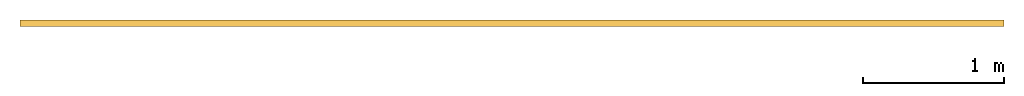
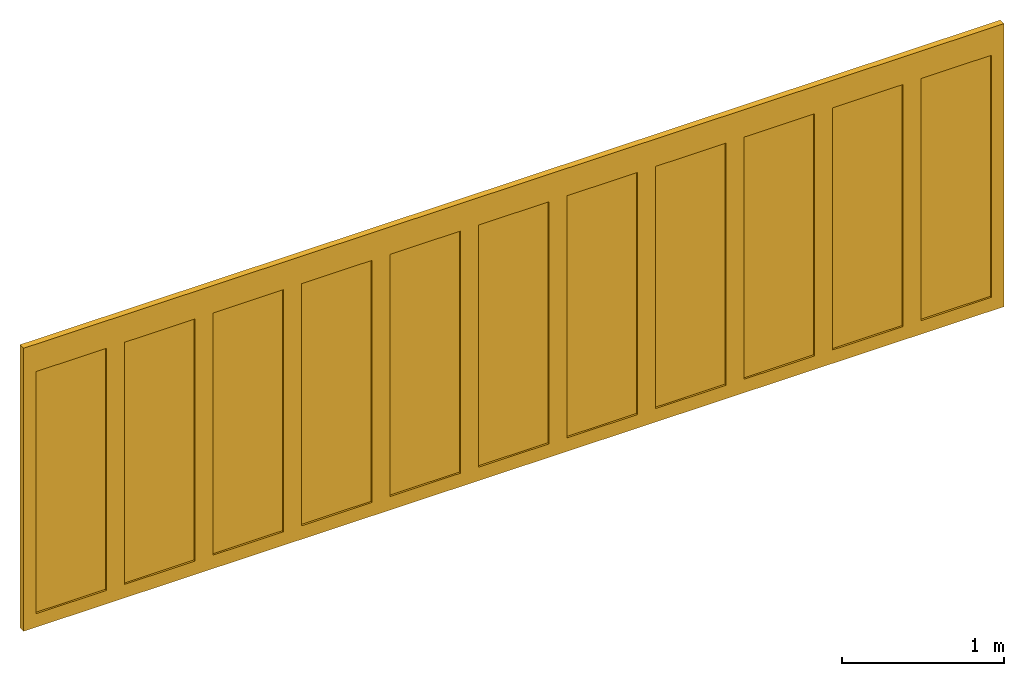
# One storey: 1 door.
"""IFC2X3 building model written with IfcOpenShell, lengths in millimetres."""

from ifc_helpers import new_model, entity, si_unit, converted_unit, direction, frame, frame_2d, origin, place, context, subcontext, project, spatial, polyline, rectangle, outline, extrude, source, transform, mapped, material, material_list, type_object, type_shapes, element, save


model = new_model("IFC2X3")

# Units and contexts
model_context = context("Model", 3, precision=1e-06, world=origin(), true_north=direction((2.0, -1.71512652170913e-15, 1.0)))
context_of_model = context(None, 3, precision=1e-06, world=origin(), true_north=direction((2.0, -1.71512652170913e-15, 1.0)))
body_context = subcontext(model_context, "Body", "Model", "MODEL_VIEW")
ifc_project = project(units=[si_unit("LENGTHUNIT", "METRE", prefix="MILLI"), si_unit("AREAUNIT", "SQUARE_METRE", prefix="MILLI"), si_unit("VOLUMEUNIT", "CUBIC_METRE", prefix="MILLI"), converted_unit("PLANEANGLEUNIT", "DEGREE", entity("IfcRatioMeasure", 0.0174532925199433), si_unit("PLANEANGLEUNIT", "RADIAN"), dimensions=[0, 0, 0, 0, 0, 0, 0]), si_unit("TIMEUNIT", "SECOND")], contexts=[model_context, context_of_model])

# Site, building, storey
site_placement = place(None, origin())
site = spatial("IfcSite", under=ifc_project, at=site_placement, CompositionType="ELEMENT")
building_placement = place(site_placement, origin())
building = spatial("IfcBuilding", under=site, at=building_placement, CompositionType="ELEMENT")
storey_placement = place(building_placement, origin())
storey = spatial("IfcBuildingStorey", under=building, at=storey_placement, Name="Ground Floor", CompositionType="ELEMENT", Elevation=0.0)

# Door
ifc_material_1 = material(Name="Glass-Blue")
ifc_material_2 = material(Name="Mtl-Aluminium")
ifc_material_list = material_list([ifc_material_1, ifc_material_2])
door_style = type_object("IfcDoorStyle", ConstructionType="NOTDEFINED", OperationType="NOTDEFINED", ParameterTakesPrecedence=False, Sizeable=False)
shared_shape = source(origin(), body_context, "Body", "SweptSolid", [
    extrude(rectangle(XDim=502.000000000001, YDim=18.0, at=frame_2d((0.0, 1.68753899743024e-14), x_axis=(1.0, 0.0))), frame((2110.3148, 277.500000000017, 65.0), z_axis=(0.0, 0.0, 1.0), x_axis=(-1.0, 0.0, 0.0)), (0.0, 0.0, 1.0), 1827.8),
    extrude(outline(polyline([(-316.0, -978.9), (316.0, -978.9), (316.0, 978.9), (-316.0, 978.9), (-316.0, -978.9)]), holes=[polyline([(251.0, 913.9), (251.0, -913.9), (-251.0, -913.9), (-251.0, 913.9), (251.0, 913.9)])]), frame((2110.3148, 255.0, 978.9), z_axis=(0.0, 1.0, 0.0), x_axis=(-1.0, 0.0, 0.0)), (0.0, 0.0, 1.0), 45.0),
    extrude(rectangle(XDim=502.0, YDim=18.0, at=frame_2d((0.0, 1.68753899743024e-14), x_axis=(1.0, 0.0))), frame((1478.3148, 277.500000000017, 65.0), z_axis=(0.0, 0.0, 1.0), x_axis=(-1.0, 0.0, 0.0)), (0.0, 0.0, 1.0), 1827.8),
    extrude(outline(polyline([(-316.0, -978.9), (316.0, -978.9), (316.0, 978.9), (-316.0, 978.9), (-316.0, -978.9)]), holes=[polyline([(251.0, 913.9), (251.0, -913.9), (-251.0, -913.9), (-251.0, 913.9), (251.0, 913.9)])]), frame((1478.3148, 255.0, 978.9), z_axis=(0.0, 1.0, 0.0), x_axis=(-1.0, 0.0, 0.0)), (0.0, 0.0, 1.0), 45.0),
    extrude(rectangle(XDim=502.0, YDim=18.0, at=frame_2d((0.0, 1.68753899743024e-14), x_axis=(1.0, 0.0))), frame((846.314800000002, 277.500000000017, 65.0), z_axis=(0.0, 0.0, 1.0), x_axis=(-1.0, 0.0, 0.0)), (0.0, 0.0, 1.0), 1827.8),
    extrude(outline(polyline([(-316.0, -978.9), (316.0, -978.9), (316.0, 978.9), (-316.0, 978.9), (-316.0, -978.9)]), holes=[polyline([(251.0, 913.9), (251.0, -913.9), (-251.0, -913.9), (-251.0, 913.9), (251.0, 913.9)])]), frame((846.314800000002, 255.0, 978.9), z_axis=(0.0, 1.0, 0.0), x_axis=(-1.0, 0.0, 0.0)), (0.0, 0.0, 1.0), 45.0),
    extrude(rectangle(XDim=502.000000000001, YDim=18.0, at=frame_2d((0.0, 1.68753899743024e-14), x_axis=(1.0, 0.0))), frame((214.314800000002, 277.500000000017, 65.0), z_axis=(0.0, 0.0, 1.0), x_axis=(-1.0, 0.0, 0.0)), (0.0, 0.0, 1.0), 1827.8),
    extrude(outline(polyline([(-316.0, -978.9), (316.0, -978.9), (316.0, 978.9), (-316.0, 978.9), (-316.0, -978.9)]), holes=[polyline([(251.0, 913.9), (251.0, -913.9), (-251.0, -913.9), (-251.0, 913.9), (251.0, 913.9)])]), frame((214.314800000002, 255.0, 978.9), z_axis=(0.0, 1.0, 0.0), x_axis=(-1.0, 0.0, 0.0)), (0.0, 0.0, 1.0), 45.0),
    extrude(rectangle(XDim=502.0, YDim=18.0, at=frame_2d((0.0, 1.68753899743024e-14), x_axis=(1.0, 0.0))), frame((-417.685199999998, 277.500000000017, 65.0), z_axis=(0.0, 0.0, 1.0), x_axis=(-1.0, 0.0, 0.0)), (0.0, 0.0, 1.0), 1827.8),
    extrude(outline(polyline([(-316.0, -978.9), (316.0, -978.9), (316.0, 978.9), (-316.0, 978.9), (-316.0, -978.9)]), holes=[polyline([(251.0, 913.9), (251.0, -913.9), (-251.0, -913.9), (-251.0, 913.9), (251.0, 913.9)])]), frame((-417.685199999998, 255.0, 978.9), z_axis=(0.0, 1.0, 0.0), x_axis=(-1.0, 0.0, 0.0)), (0.0, 0.0, 1.0), 45.0),
    extrude(rectangle(XDim=502.0, YDim=18.0, at=frame_2d((0.0, 1.68753899743024e-14), x_axis=(1.0, 0.0))), frame((-1049.6852, 277.500000000017, 65.0), z_axis=(0.0, 0.0, 1.0), x_axis=(-1.0, 0.0, 0.0)), (0.0, 0.0, 1.0), 1827.8),
    extrude(outline(polyline([(-316.0, -978.9), (316.0, -978.9), (316.0, 978.9), (-316.0, 978.9), (-316.0, -978.9)]), holes=[polyline([(251.0, 913.9), (251.0, -913.9), (-251.0, -913.9), (-251.0, 913.9), (251.0, 913.9)])]), frame((-1049.6852, 255.0, 978.9), z_axis=(0.0, 1.0, 0.0), x_axis=(-1.0, 0.0, 0.0)), (0.0, 0.0, 1.0), 45.0),
    extrude(rectangle(XDim=502.0, YDim=18.0, at=frame_2d((-2.70006239588838e-13, 1.68753899743024e-14), x_axis=(1.0, 0.0))), frame((-1681.6852, 277.500000000017, 65.0), z_axis=(0.0, 0.0, 1.0), x_axis=(-1.0, 0.0, 0.0)), (0.0, 0.0, 1.0), 1827.8),
    extrude(outline(polyline([(-316.0, -978.9), (316.0, -978.9), (316.0, 978.9), (-316.0, 978.9), (-316.0, -978.9)]), holes=[polyline([(251.0, 913.9), (251.0, -913.9), (-251.0, -913.9), (-251.0, 913.9), (251.0, 913.9)])]), frame((-1681.6852, 255.0, 978.9), z_axis=(0.0, 1.0, 0.0), x_axis=(-1.0, 0.0, 0.0)), (0.0, 0.0, 1.0), 45.0),
    extrude(rectangle(XDim=502.0, YDim=18.0, at=frame_2d((0.0, 1.68753899743024e-14), x_axis=(1.0, 0.0))), frame((-2313.6852, 277.500000000017, 65.0), z_axis=(0.0, 0.0, 1.0), x_axis=(-1.0, 0.0, 0.0)), (0.0, 0.0, 1.0), 1827.8),
    extrude(outline(polyline([(-316.0, -978.9), (316.0, -978.9), (316.0, 978.9), (-316.0, 978.9), (-316.0, -978.9)]), holes=[polyline([(251.0, 913.9), (251.0, -913.9), (-251.0, -913.9), (-251.0, 913.9), (251.0, 913.9)])]), frame((-2313.6852, 255.0, 978.9), z_axis=(0.0, 1.0, 0.0), x_axis=(-1.0, 0.0, 0.0)), (0.0, 0.0, 1.0), 45.0),
    extrude(rectangle(XDim=502.0, YDim=18.0, at=frame_2d((0.0, 1.68753899743024e-14), x_axis=(1.0, 0.0))), frame((-2945.6852, 277.500000000017, 65.0), z_axis=(0.0, 0.0, 1.0), x_axis=(-1.0, 0.0, 0.0)), (0.0, 0.0, 1.0), 1827.8),
    extrude(outline(polyline([(-316.0, -978.9), (316.0, -978.9), (316.0, 978.9), (-316.0, 978.9), (-316.0, -978.9)]), holes=[polyline([(251.0, 913.9), (251.0, -913.9), (-251.0, -913.9), (-251.0, 913.9), (251.0, 913.9)])]), frame((-2945.6852, 255.0, 978.9), z_axis=(0.0, 1.0, 0.0), x_axis=(-1.0, 0.0, 0.0)), (0.0, 0.0, 1.0), 45.0),
    extrude(rectangle(XDim=502.0, YDim=18.0, at=frame_2d((2.70006239588838e-13, 1.68753899743024e-14), x_axis=(1.0, 0.0))), frame((-3577.6852, 277.500000000017, 65.0), z_axis=(0.0, 0.0, 1.0), x_axis=(-1.0, 0.0, 0.0)), (0.0, 0.0, 1.0), 1827.8),
    extrude(outline(polyline([(-316.0, -978.9), (316.0, -978.9), (316.0, 978.9), (-316.0, 978.9), (-316.0, -978.9)]), holes=[polyline([(251.0, 913.9), (251.0, -913.9), (-251.0, -913.9), (-251.0, 913.9), (251.0, 913.9)])]), frame((-3577.6852, 255.0, 978.9), z_axis=(0.0, 1.0, 0.0), x_axis=(-1.0, 0.0, 0.0)), (0.0, 0.0, 1.0), 45.0),
    extrude(rectangle(XDim=502.0, YDim=18.0, at=frame_2d((-2.70006239588838e-13, 1.68753899743024e-14), x_axis=(1.0, 0.0))), frame((-4209.6852, 277.500000000017, 65.0), z_axis=(0.0, 0.0, 1.0), x_axis=(-1.0, 0.0, 0.0)), (0.0, 0.0, 1.0), 1827.8),
    extrude(outline(polyline([(-316.0, -978.9), (316.0, -978.9), (316.0, 978.9), (-316.0, 978.9), (-316.0, -978.9)]), holes=[polyline([(251.0, 913.9), (251.0, -913.9), (-251.0, -913.9), (-251.0, 913.9), (251.0, 913.9)])]), frame((-4209.6852, 255.0, 978.9), z_axis=(0.0, 1.0, 0.0), x_axis=(-1.0, 0.0, 0.0)), (0.0, 0.0, 1.0), 45.0),
    extrude(rectangle(XDim=24.0, YDim=45.0, at=frame_2d((0.0, -1.59872115546023e-14), x_axis=(1.0, 0.0))), frame((-4537.6852, 277.500000000017, 0.0), z_axis=(0.0, 0.0, 1.0), x_axis=(-1.0, 0.0, 0.0)), (0.0, 0.0, 1.0), 1957.8),
    extrude(rectangle(XDim=24.0, YDim=45.0, at=frame_2d((0.0, -1.59872115546023e-14), x_axis=(1.0, 0.0))), frame((2438.3148, 277.500000000017, 0.0), z_axis=(0.0, 0.0, 1.0), x_axis=(-1.0, 0.0, 0.0)), (0.0, 0.0, 1.0), 1957.8),
    extrude(rectangle(XDim=7000.0, YDim=45.0, at=frame_2d((0.0, -1.59872115546023e-14), x_axis=(1.0, 0.0))), frame((-1049.6852, 277.500000000017, 1957.8), z_axis=(0.0, 0.0, 1.0), x_axis=(-1.0, 0.0, 0.0)), (0.0, 0.0, 1.0), 142.2),
    extrude(rectangle(XDim=7000.0, YDim=45.0, at=frame_2d((0.0, -1.59872115546023e-14), x_axis=(1.0, 0.0))), frame((-1049.6852, 277.500000000017, -37.0), z_axis=(0.0, 0.0, 1.0), x_axis=(-1.0, 0.0, 0.0)), (0.0, 0.0, 1.0), 37.0),
])
type_shapes(door_style, [shared_shape])
door_placement = place(storey_placement, origin())
element("IfcDoor", 1, at=door_placement, inside=storey, type_object=door_style, material=ifc_material_list, OverallHeight=2137.0, OverallWidth=7000.0, context=body_context, shape_type="MappedRepresentation", body=[
    mapped(shared_shape, transform((0.0, 0.0, 0.0), scale=1.0)),
])

save(model, "model.ifc")
